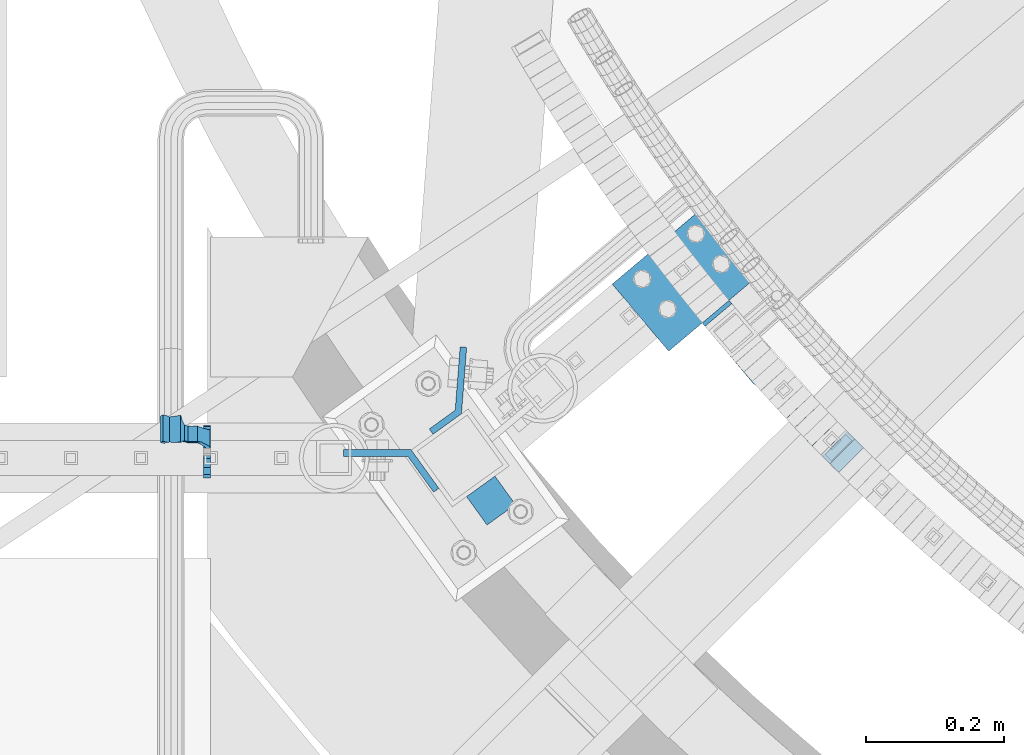
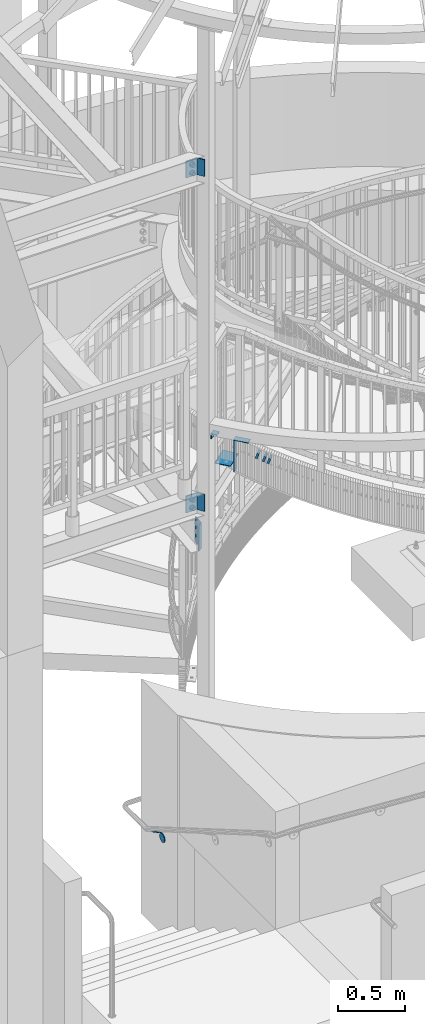
# One storey, part 465 of 975: 11 beams.
"""IFC2X3 building model written with IfcOpenShell, lengths in millimetres."""

from ifc_helpers import new_model, si_unit, frame, origin_with_axes, place, context, subcontext, project, spatial, faceted_brep, material, type_object, element, save


model = new_model("IFC2X3")

# Units and contexts
model_context = context("Model", 3, precision=1e-05, world=origin_with_axes())
body_context = subcontext(model_context, "Body", "Model", "MODEL_VIEW")
ifc_project = project(units=[si_unit("LENGTHUNIT", "METRE", prefix="MILLI"), si_unit("AREAUNIT", "SQUARE_METRE"), si_unit("VOLUMEUNIT", "CUBIC_METRE"), si_unit("MASSUNIT", "GRAM", prefix="KILO"), si_unit("TIMEUNIT", "SECOND"), si_unit("PLANEANGLEUNIT", "RADIAN"), si_unit("SOLIDANGLEUNIT", "STERADIAN"), si_unit("THERMODYNAMICTEMPERATUREUNIT", "DEGREE_CELSIUS"), si_unit("LUMINOUSINTENSITYUNIT", "LUMEN")], contexts=[model_context])

# Site, building, storey
site_placement = place(None, origin_with_axes())
site = spatial("IfcSite", under=ifc_project, at=site_placement, CompositionType="ELEMENT")
building_placement = place(site_placement, origin_with_axes())
building = spatial("IfcBuilding", under=site, at=building_placement, Name="Undefined", CompositionType="ELEMENT")
storey_placement = place(building_placement, origin_with_axes())
storey = spatial("IfcBuildingStorey", under=building, at=storey_placement, Name="Undefined", CompositionType="ELEMENT", Elevation=0.0)

# Beams
ifc_material_1 = material()
beam_type_1 = type_object("IfcBeamType", Name="HSS2X2X.188_TUBES", PredefinedType="NOTDEFINED")
beam_1_placement = place(storey_placement, frame((32635.866540343, 1445.02229423735, 4036.54607665717), z_axis=(0.729187266859689, 0.684314204039121, 4.05166247219314e-11), x_axis=(0.650743024858308, -0.693414698849034, -0.309369634932654)))
element("IfcBeam", 1, at=beam_1_placement, inside=storey, type_object=beam_type_1, material=ifc_material_1, Name="WALL", ObjectType="HSS2X2X.188_TUBES", context=body_context, shape_type="Brep", body=[
    faceted_brep([(0.0, 20.6374999999753, -20.6375000000298), (0.0, -20.6375000000153, -20.6375000000153), (18.7547327359644, -20.6374999999844, -20.6375000000553), (18.7547327359898, 20.6375000000171, -20.6375000000335), (0.0, -20.6374999999825, 20.6375000000335), (18.7547327360044, -20.6374999999953, 20.6374999999898), (0.0, 20.6375000000116, 20.6375000000189), (18.7547327360262, 20.6375000000062, 20.6375000000116), (0.0, 25.3999999999724, -25.4000000000342), (0.0, 25.400000000016, 25.4000000000196), (18.7547327360371, 25.4000000000033, 25.4000000000124), (18.7547327359898, 25.4000000000178, -25.4000000000342), (0.0, -25.399999999976, 25.4000000000378), (18.7547327360044, -25.399999999996, 25.3999999999869), (0.0, -25.400000000016, -25.4000000000196), (18.7547327359498, -25.3999999999814, -25.4000000000597)], [[[0, 1, 2, 3]], [[1, 4, 5, 2]], [[4, 6, 7, 5]], [[6, 0, 3, 7]], [[8, 9, 10, 11]], [[9, 12, 13, 10]], [[12, 14, 15, 13]], [[14, 8, 11, 15]], [[13, 15, 11, 10], [5, 7, 3, 2]], [[14, 12, 9, 8], [6, 4, 1, 0]]]),
])
beam_2_placement = place(storey_placement, frame((32673.1203491653, 1405.73165556742, 4019.33794755332), z_axis=(0.715441150850819, 0.698672999098474, 5.66296876058913e-11), x_axis=(0.664621009862591, -0.680571913859291, -0.308384148936246)))
element("IfcBeam", 2, at=beam_2_placement, inside=storey, type_object=beam_type_1, material=ifc_material_1, Name="WALL", ObjectType="HSS2X2X.188_TUBES", context=body_context, shape_type="Brep", body=[
    faceted_brep([(0.0, 20.6374999999753, -20.6375000000298), (0.0, -20.6375000000153, -20.6375000000153), (18.8066477608099, -20.6374999999862, -20.6375000000116), (18.8066477608172, 20.6375000000062, -20.6374999999971), (0.0, -20.6374999999825, 20.6375000000335), (18.8066477608463, -20.6375000000062, 20.6375000000407), (0.0, 20.6375000000116, 20.6375000000189), (18.8066477608536, 20.6374999999844, 20.637500000048), (0.0, 25.3999999999724, -25.4000000000342), (0.0, 25.400000000016, 25.4000000000196), (18.8066477608591, 25.3999999999814, 25.400000000056), (18.8066477608154, 25.4000000000051, -25.4000000000015), (0.0, -25.399999999976, 25.4000000000378), (18.8066477608518, -25.4000000000087, 25.4000000000451), (0.0, -25.400000000016, -25.4000000000196), (18.8066477608081, -25.3999999999851, -25.4000000000196)], [[[0, 1, 2, 3]], [[1, 4, 5, 2]], [[4, 6, 7, 5]], [[6, 0, 3, 7]], [[8, 9, 10, 11]], [[9, 12, 13, 10]], [[12, 14, 15, 13]], [[14, 8, 11, 15]], [[13, 15, 11, 10], [5, 7, 3, 2]], [[14, 12, 9, 8], [6, 4, 1, 0]]]),
])
beam_3_placement = place(storey_placement, frame((32698.4030412457, 1380.05847658687, 4007.79871465884), z_axis=(0.709896124735853, 0.704306390773943, -2.16257376450812e-10), x_axis=(0.671067713910054, -0.676393648909327, -0.303578251959294)))
element("IfcBeam", 3, at=beam_3_placement, inside=storey, type_object=beam_type_1, material=ifc_material_1, Name="WALL", ObjectType="HSS2X2X.188_TUBES", context=body_context, shape_type="Brep", body=[
    faceted_brep([(0.0, 20.6374999999753, -20.6375000000298), (0.0, -20.6375000000153, -20.6375000000153), (18.7771137292038, -20.637500000008, -20.6374999999862), (18.777113729182, 20.6375000000062, -20.6375000000189), (0.0, -20.6374999999825, 20.6375000000335), (18.7771137291729, -20.6374999999916, 20.6374999999753), (0.0, 20.6375000000116, 20.6375000000189), (18.7771137291529, 20.6375000000207, 20.6374999999389), (0.0, 25.3999999999724, -25.4000000000342), (0.0, 25.400000000016, 25.4000000000196), (18.7771137291475, 25.4000000000251, 25.3999999999287), (18.7771137291857, 25.4000000000051, -25.4000000000196), (0.0, -25.399999999976, 25.4000000000378), (18.7771137291711, -25.3999999999905, 25.3999999999724), (0.0, -25.400000000016, -25.4000000000196), (18.7771137292129, -25.4000000000124, -25.3999999999724)], [[[0, 1, 2, 3]], [[1, 4, 5, 2]], [[4, 6, 7, 5]], [[6, 0, 3, 7]], [[8, 9, 10, 11]], [[9, 12, 13, 10]], [[12, 14, 15, 13]], [[14, 8, 11, 15]], [[13, 15, 11, 10], [5, 7, 3, 2]], [[14, 12, 9, 8], [6, 4, 1, 0]]]),
])
ifc_material_2 = material(Name="STEEL/A36")
beam_type_2 = type_object("IfcBeamType", PredefinedType="NOTDEFINED")
beam_4_placement = place(storey_placement, frame((31778.574969517, 1373.95484456894, 883.216794476958), z_axis=(0.0, -0.863778825965781, 0.50387115398004), x_axis=(1.0, 0.0, 0.0)))
element("IfcBeam", 4, at=beam_4_placement, inside=storey, type_object=beam_type_2, material=ifc_material_2, Name="WALL BRACKET", context=body_context, shape_type="Brep", body=[
    faceted_brep([(-1.09139364212751e-11, -35.1998101886752, 14.5802387730655), (0.0, -26.940768363208, 26.9407683632162), (1.2732925824821e-11, -14.5802387731151, 35.1998101887366), (0.0, 0.0, 38.0999984741211), (3.27418092638254e-11, 14.5802387730973, 35.1998101888166), (3.45607986673713e-11, 26.9407683631939, 26.9407683633472), (3.27418092638254e-11, 35.1998101886679, 14.5802387732328), (2.36468622460961e-11, 38.0999999999908, 8.73114913702011e-11), (1.45519152283669e-11, 35.1998101886752, -14.5802387730655), (1.81898940354586e-12, 26.9407683632071, -26.9407683632162), (-1.09139364212751e-11, 14.5802387731146, -35.1998101887511), (0.0, 0.0, -38.0999984741211), (-2.91038304567337e-11, -14.5802387730978, -35.1998101888239), (-3.27418092638254e-11, -26.9407683631948, -26.9407683633617), (-3.09228198602796e-11, -35.1998101886688, -14.5802387732401), (-2.36468622460961e-11, -38.0999999999917, -9.45874489843845e-11), (9.52499999999407, 35.4440469783465, 13.3523775149006), (9.52500000001783, 38.099999999989, 1.23691279441118e-10), (5.45819490078651, 35.1998101886775, 14.58023877304), (5.15915812204861, 35.4440469814256, 13.3523774994246), (5.15916016817869, 35.4440461871586, -13.3523814925829), (5.45819607316758, 35.1998101886757, -14.5802387731565), (9.52499999563867, 35.4440461839649, -13.352381508641), (9.52499999999338, 33.7468954266617, -16.754679378646), (9.52499999999418, 26.9407683632057, -26.9407683631944), (7.23710514487385, 33.7468954167059, -16.7546793935435), (9.52499999997963, 14.5802387731133, -35.199810188722), (9.52499999996871, 7.73070496506989e-12, -38.1000000000931), (9.52499999996326, -14.5802387730996, -35.1998101888021), (9.52499999995962, -26.9407683631966, -26.9407683633399), (9.5249999999578, -35.1998101886768, -14.5802387731064), (9.52499999997235, -38.0999999999935, -7.27595761418343e-11), (9.52499999988504, -35.1998101886779, 14.5802387731401), (9.52499999999418, -26.9407683632098, 26.940768363238), (9.52500000000691, -14.5802387731169, 35.1998101887584), (9.52500000001783, -1.13686837721616e-11, 38.1000000001295), (9.5250000000251, 14.580238773096, 35.1998101888312), (9.52500000002692, 26.9407683631925, 26.9407683633617), (7.23710629084189, 33.7468933804012, 16.7546824409801), (9.52500001802099, 33.74689339, 16.7546824266137), (4.12737783423069, 36.2867482851609, 11.6630037101459), (9.52500001480979, 36.2867482910076, 11.6630037099276), (1.9072828969438, 38.0999998001848, -4.3824766180478e-06), (9.43529109937867, 38.0999998083389, -4.38277129433118e-06), (4.12738199474541, 36.2867456530334, -11.6630120660157), (9.52499999713365, 36.2867456588801, -11.6630120662267), (9.52499998931302, 31.8782691818908, -20.5007361535354), (1.90728516843444, 38.0999984362613, -14.9620414784949), (9.43529504267332, 38.0999984471014, -14.9620414798228), (9.52499998867484, 31.8782692100656, -21.3428983101403), (-0.974480980704527, 40.4536660864392, -13.6176374922397), (6.55352889353486, 40.4536660972792, -13.617637493564), (-3.23293929398841, 48.4467136552532, -12.2071016444133), (-3.86099316375032, 48.9596734302611, -12.3332393299024), (-3.86099415506237, 48.9596734359397, 12.1506042690053), (-3.23294234398753, 48.4467162038179, 12.0244673261113), (6.55352388489973, 40.4536689343606, 13.4350048968336), (9.4352891744017, 38.1000015670843, 14.7794093900302), (-8.88876894391092, 51.462646060533, -12.9487245784876), (-14.5044020842531, 51.5524567377918, -12.9708091785214), (-14.5044031272276, 51.5524567437842, 12.788173508583), (-8.88876998507754, 51.4626460665079, 12.7660889411018), (-16.4483770195459, 51.1442726592504, -12.8704360163174), (-16.4483780543928, 51.1442726651987, 12.6878004343525), (-22.5793182144077, 51.3711360271759, -12.9262221073186), (-22.5793192537777, 51.3711360331463, 12.7435864607032), (-27.8885284154861, 54.4455780358899, -13.6822326528272), (-27.8885295160832, 54.4455780422152, 13.4995963000001), (-28.6196515649072, 55.6169452716154, -13.9702738582564), (-31.1370083013608, 59.6501226213948, -17.5950925222933), (-31.1370097188383, 59.6501226295447, 17.4124524185645), (-28.6196545294583, 55.616948227025, 13.7876379643458), (-33.6296792490059, 67.324805151891, -22.2250062266612), (-32.8101722890036, 64.8016260361878, -22.2250061928717), (-39.3161821982224, 64.9509398614337, -22.2250064563596), (-33.6296810489844, 67.3248051619378, 22.2249937734341), (-39.3127719838823, 64.95236112884, 22.2249935438595), (-32.8101756191698, 64.8016307577993, 22.2249938072164), (-49.8281982508399, 63.7590297560901, -21.2879733583577), (-49.8281999673757, 63.7590297658239, 21.1053316176076), (-62.537662592724, 64.8016282183019, -22.2250073966388), (-62.5376643923654, 64.8016282284259, 22.2249926034456), (-59.3629825026719, 68.3509998487543, 22.2249927311568), (-59.3629807030303, 68.3509998386305, -22.2250072689349), (-56.0005505059879, 61.6533412669896, 22.2249928688907), (-56.0009816237271, 61.6535489521873, 19.2130312653135), (-56.0009816302269, 64.8016307505561, 22.0423689734525), (-51.9930603186979, 64.8016307660225, 22.2249930304133), (-51.9930486616773, 64.8016260085653, -22.2250069696784), (-56.000981616694, 61.6535497473442, -22.2250071312228), (-56.0009816212363, 64.8016260027941, -22.2250068759422), (-56.0009816161877, 61.6535496925769, -19.3956728877092), (-50.6240356350016, 59.0640018412871, -17.0683164176735), (-50.6240370098228, 59.0640018490833, 16.8856764812081), (-37.4851004069614, 60.555058921409, -18.4084041452843), (-37.4851018904596, 60.555058929803, 18.2257636742615), (-36.5628425975134, 60.9400579463424, -18.7544220673662), (-36.5628441090176, 60.9400579547794, 18.5717814508498), (-35.6661101826384, 58.1791091500552, -16.2730189810172), (-35.6661114930633, 58.1791091575863, 16.0903794298065), (-34.0669073739811, 55.616948225869, 13.7876379531408), (-34.0669044052501, 55.6169452637716, -13.9702738572996), (-31.199578137138, 51.0230652214489, -12.8406309028251), (-31.1995791695818, 51.0230652273826, 12.6579953160217), (-13.5258453474495, 46.8920843628518, -12.4814476045976), (-10.0158535806146, 46.8359491542703, -12.491353805628), (-10.0158545847443, 46.8359491600327, 12.308720278641), (-13.5258463507973, 46.8920843686235, 12.298814059428), (-15.4698202757649, 46.4839002842855, -12.5534799881534), (-15.469821284944, 46.4839002900824, 12.3708465294185), (-23.8996230795056, 46.7958284847284, -12.4984339079674), (-23.8996240842331, 46.7958284904998, 12.3158003666576), (-26.7505131823156, 48.4467136213889, -12.207101640266), (-26.7505186046602, 48.4467161988273, 12.0244672777189), (-6.87329577845111, 45.2714927334573, -12.7674339683217), (-6.87329680492121, 45.2714927393397, 12.584800790275), (-0.974485553301008, 40.4536689327629, 13.4350048813394), (1.90728014135857, 38.100001565487, 14.7794093745397), (9.52500002100476, 31.8782677827221, 21.320715892205), (9.52500002038346, 31.878267810155, 20.5007393728483)], [[[0, 1, 2, 3, 4, 5, 6, 7, 8, 9, 10, 11, 12, 13, 14, 15]], [[16, 17, 7, 6, 18, 19]], [[20, 21, 8, 7, 17, 22]], [[23, 24, 9, 8, 21, 25]], [[10, 9, 24, 26]], [[11, 10, 26, 27]], [[12, 11, 27, 28]], [[13, 12, 28, 29]], [[14, 13, 29, 30]], [[15, 14, 30, 31]], [[0, 15, 31, 32]], [[1, 0, 32, 33]], [[2, 1, 33, 34]], [[3, 2, 34, 35]], [[4, 3, 35, 36]], [[5, 4, 36, 37]], [[38, 18, 6, 5, 37, 39]], [[39, 37, 36, 35, 34, 33, 32, 31, 30, 29, 28, 27, 26, 24, 23, 22, 17, 16]], [[40, 41, 16, 19]], [[40, 42, 43, 41]], [[42, 44, 45, 43]], [[46, 23, 25]], [[47, 48, 49]], [[48, 47, 50, 51]], [[51, 52, 53, 54, 55, 56, 57, 48]], [[58, 59, 60, 61]], [[59, 62, 63, 60]], [[62, 64, 65, 63]], [[64, 66, 67, 65]], [[66, 68, 69, 70, 71, 67]], [[72, 73, 74]], [[75, 76, 77]], [[74, 76, 75, 72]], [[74, 78, 79, 76]], [[80, 81, 82, 83]], [[84, 85, 86]], [[82, 81, 84, 86, 87]], [[78, 88, 83, 82, 87, 79]], [[89, 80, 83, 88, 90]], [[89, 90, 91]], [[84, 81, 80, 89, 91, 92, 93, 85]], [[92, 94, 95, 93]], [[94, 96, 97, 95]], [[96, 98, 99, 97]], [[70, 77, 76, 79, 87, 86, 85, 93, 95, 97, 99, 100, 71]], [[69, 73, 72, 75, 77, 70]], [[68, 101, 98, 96, 94, 92, 91, 90, 88, 78, 74, 73, 69]], [[99, 98, 101, 102, 103, 100]], [[104, 105, 106, 107]], [[108, 104, 107, 109]], [[110, 108, 109, 111]], [[103, 102, 112, 110, 111, 113]], [[54, 61, 60, 63, 65, 67, 71, 100, 103, 113, 55]], [[53, 58, 61, 54]], [[52, 112, 102, 101, 68, 66, 64, 62, 59, 58, 53]], [[51, 50, 114, 105, 104, 108, 110, 112, 52]], [[105, 114, 115, 106]], [[55, 113, 111, 109, 107, 106, 115, 116, 56]], [[56, 116, 117, 57]], [[117, 118, 57]], [[39, 16, 41, 43, 45, 22, 23, 46, 49, 48, 57, 118, 119]], [[119, 38, 39]], [[119, 118, 117, 116, 115, 114, 50, 47, 49, 46, 25, 21, 20, 44, 42, 40, 19, 18, 38]], [[45, 44, 20, 22]]]),
])
beam_type_3 = type_object("IfcBeamType", Name="L2X2X1/4", PredefinedType="NOTDEFINED")
beam_5_placement = place(storey_placement, frame((32174.2283218151, 1288.3825650108, 4444.99999705359), z_axis=(0.584817065277228, -0.811165211384543, 0.0), x_axis=(0.811165211384543, 0.584817065277228, 0.0)))
element("IfcBeam", 5, at=beam_5_placement, inside=storey, type_object=beam_type_3, material=ifc_material_2, Name="ANGLE", ObjectType="L2X2X1/4", context=body_context, shape_type="Brep", body=[
    faceted_brep([(0.0, 25.3999999999724, -25.4000000000342), (0.0, 25.400000000016, 25.4000000000196), (50.8000000000102, 25.3999999999996, 25.4000000000015), (50.7999999999411, 25.3999999999996, -25.4000000000487), (3.27418092638254e-11, 19.0500000000002, 25.4000000000269), (50.8000000000102, 19.0500000000002, 25.4000000000015), (-2.5465851649642e-11, 19.0500000000002, -19.0500000000211), (50.7999999999483, 19.0500000000002, -19.0500000000429), (-2.5465851649642e-11, -25.3999999999996, -19.0500000000211), (50.7999999999483, -25.3999999999996, -19.0500000000429), (0.0, -25.400000000016, -25.4000000000196), (50.7999999999411, -25.3999999999996, -25.4000000000487)], [[[0, 1, 2, 3]], [[1, 4, 5, 2]], [[4, 6, 7, 5]], [[6, 8, 9, 7]], [[8, 10, 11, 9]], [[10, 0, 3, 11]], [[5, 7, 9, 11, 3, 2]], [[10, 8, 6, 4, 1, 0]]]),
])
beam_type_4 = type_object("IfcBeamType", PredefinedType="NOTDEFINED")
for number, where, z_axis, x_axis, name in (
    (6, (32115.5187184618, 1318.22655085139, 3848.10000305176), (0.0, 0.0, 1.0), (-0.584817058957379, 0.811165215940897, 0.0), "BENT_PLATE"),
    (7, (32115.5185691597, 1318.23944776752, 6896.10000305176), (0.0, 0.0, 1.0), (-0.584817058957379, 0.811165215940897, 0.0), "BENT_PLATE"),
):
    element("IfcBeam", number, at=place(storey_placement, frame(where, z_axis=z_axis, x_axis=x_axis)), inside=storey, type_object=beam_type_4, material=ifc_material_2, Name=name, context=body_context, shape_type="Brep", body=[
        faceted_brep([(1.26819941215217e-07, -4.762500000008, -76.1999999999998), (1.26819941215217e-07, -4.762500000008, 76.1999999999998), (-1.26819941215217e-07, 4.76250000000437, 76.1999999999998), (-1.26819941215217e-07, 4.76250000000437, -76.1999999999998), (64.0251172252938, 4.76250170491039, 76.1999999999998), (64.0251172252938, 4.76250170491039, -76.1999999999998), (68.9003478626837, -4.7624981652807, -76.1999999999998), (68.9003478626837, -4.7624981652807, 76.1999999999998), (118.304401177997, 80.0500894313409, 76.1999999999998), (118.304401177997, 80.0500894313409, -76.1999999999998), (126.030749772293, 74.4797068233456, 76.1999999999998), (126.030749772293, 74.4797068233456, -76.1999999999998)], [[[0, 1, 2, 3]], [[3, 2, 4, 5]], [[1, 0, 6, 7]], [[5, 4, 8, 9]], [[4, 2, 1, 7, 10, 8]], [[7, 6, 11, 10]], [[6, 0, 3, 5, 9, 11]], [[10, 11, 9, 8]]]),
    ])
beam_type_5 = type_object("IfcBeamType", PredefinedType="NOTDEFINED")
beam_6_placement = place(storey_placement, frame((32520.2722864416, 1576.994923404, 4137.55701770363), z_axis=(0.76502246600244, 0.644003592002052, 0.0), x_axis=(0.644003592002055, -0.765022466002437, -1.9999996069305e-09)))
element("IfcBeam", 8, at=beam_6_placement, inside=storey, type_object=beam_type_5, material=ifc_material_2, Name="PLATE", context=body_context, shape_type="Brep", body=[
    faceted_brep([(0.0, 3.17500000000018, -25.4000000000051), (1.09139364212751e-11, 3.17500000000018, 25.4000000000087), (116.609521863611, 3.17499999999745, 25.4000000000306), (116.609521863596, 3.17499999999745, -25.3999999999833), (1.09139364212751e-11, -3.17500000000018, 25.4000000000087), (116.609521863607, -3.175000000002, 25.4000000000306), (0.0, -3.17500000000018, -25.4000000000051), (116.609521863596, -3.175000000002, -25.3999999999869)], [[[0, 1, 2, 3]], [[1, 4, 5, 2]], [[4, 6, 7, 5]], [[6, 0, 3, 7]], [[5, 7, 3, 2]], [[6, 4, 1, 0]]]),
])
beam_7_placement = place(storey_placement, frame((32522.3169979009, 1574.56597706041, 4134.38201770359), z_axis=(-0.765022466002439, -0.644003592002053, 0.0), x_axis=(0.0, 0.0, -1.0)))
element("IfcBeam", 9, at=beam_7_placement, inside=storey, type_object=beam_type_5, material=ifc_material_2, Name="PLATE", context=body_context, shape_type="Brep", body=[
    faceted_brep([(0.0, 3.17500000000018, -25.4000000000051), (1.09139364212751e-11, 3.17500000000018, 25.4000000000087), (285.179603951159, 3.17499999999927, 25.4000000000015), (285.179603951159, 3.17500000001019, -25.4000000000124), (1.09139364212751e-11, -3.17500000000018, 25.4000000000087), (285.179603951159, -3.17500000000291, 25.4000000000051), (0.0, -3.17500000000018, -25.4000000000051), (285.179603951159, -3.17499999998836, -25.4000000000087)], [[[0, 1, 2, 3]], [[1, 4, 5, 2]], [[4, 6, 7, 5]], [[6, 0, 3, 7]], [[5, 7, 3, 2]], [[6, 4, 1, 0]]]),
])
beam_type_6 = type_object("IfcBeamType", PredefinedType="NOTDEFINED")
beam_8_placement = place(storey_placement, frame((32520.2722864963, 1576.99492338997, 3940.175), z_axis=(0.76502246600244, 0.644003592002052, 0.0), x_axis=(-0.644003592002054, 0.765022466002438, 0.0)))
element("IfcBeam", 10, at=beam_8_placement, inside=storey, type_object=beam_type_6, material=ifc_material_2, Name="PLATE", context=body_context, shape_type="Brep", body=[
    faceted_brep([(2.5465851649642e-11, 3.17500000000018, -88.9000000000269), (-2.5465851649642e-11, 3.17500000000018, 88.9000000000233), (126.999999999989, 3.17500000000018, 88.9000000000051), (127.00000000004, 3.17500000000018, -88.9000000000487), (-2.5465851649642e-11, -3.17500000000018, 88.9000000000233), (126.999999999989, -3.17500000000018, 88.9000000000051), (2.5465851649642e-11, -3.17500000000018, -88.9000000000269), (127.00000000004, -3.17500000000018, -88.9000000000487)], [[[0, 1, 2, 3]], [[1, 4, 5, 2]], [[4, 6, 7, 5]], [[6, 0, 3, 7]], [[5, 7, 3, 2]], [[6, 4, 1, 0]]]),
])
beam_type_7 = type_object("IfcBeamType", PredefinedType="NOTDEFINED")
beam_9_placement = place(storey_placement, frame((32108.0806499507, 1403.12928147806, 3473.45), z_axis=(0.0, 0.0, 1.0), x_axis=(0.811165211384543, 0.584817065277228, 0.0)))
element("IfcBeam", 11, at=beam_9_placement, inside=storey, type_object=beam_type_7, material=ifc_material_2, Name="BENT_PLATE", context=body_context, shape_type="Brep", body=[
    faceted_brep([(7.56699591875076e-08, -4.76250000000437, -114.3), (0.0, -4.76249999999982, 114.300003051758), (0.0, 4.76249999999982, 114.300003051758), (-7.56735971663147e-08, 4.76250000000437, -114.3), (46.3839221656453, 4.76250134050497, 114.3), (46.3839221656453, 4.76250134050497, -114.3), (50.7999994912389, -4.76249853187983, -114.3), (50.7999994912389, -4.76249853187983, 114.3), (105.963079350226, 75.1345707882974, 114.3), (105.963079350226, 75.1345707882974, -114.3), (113.232623948534, 68.9799508704382, 114.3), (113.232623948534, 68.9799508704382, -114.3)], [[[0, 1, 2, 3]], [[3, 2, 4, 5]], [[1, 0, 6, 7]], [[5, 4, 8, 9]], [[4, 2, 1, 7, 10, 8]], [[7, 6, 11, 10]], [[6, 0, 3, 5, 9, 11]], [[10, 11, 9, 8]]]),
])

save(model, "model.ifc")
